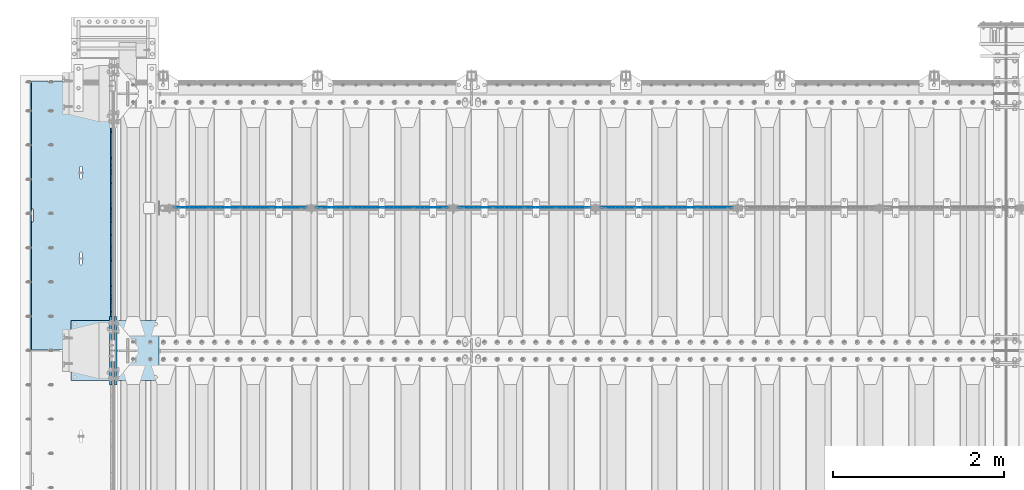
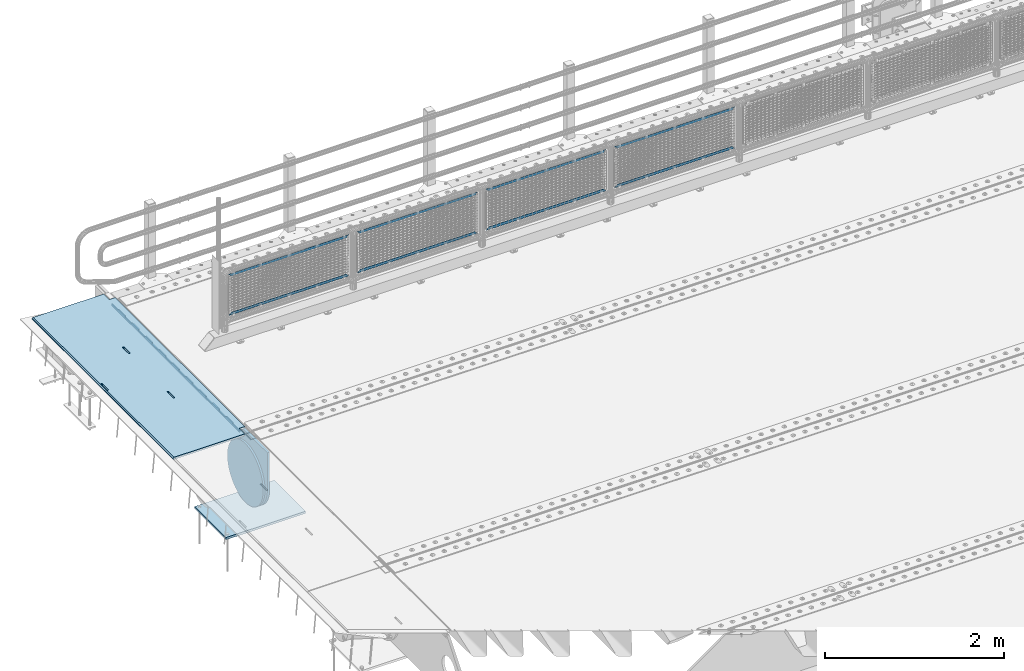
# One storey, part 188 of 240: 13 plates.
"""IFC2X3 building model written with IfcOpenShell, lengths in millimetres."""

from ifc_helpers import new_model, si_unit, frame, origin_with_axes, place, context, subcontext, project, spatial, faceted_brep, material, type_object, element, save


model = new_model("IFC2X3")

# Units and contexts
model_context = context("Model", 3, precision=1e-05, world=origin_with_axes())
body_context = subcontext(model_context, "Body", "Model", "MODEL_VIEW")
ifc_project = project(units=[si_unit("LENGTHUNIT", "METRE", prefix="MILLI"), si_unit("AREAUNIT", "SQUARE_METRE"), si_unit("VOLUMEUNIT", "CUBIC_METRE"), si_unit("MASSUNIT", "GRAM", prefix="KILO"), si_unit("TIMEUNIT", "SECOND"), si_unit("PLANEANGLEUNIT", "RADIAN"), si_unit("SOLIDANGLEUNIT", "STERADIAN"), si_unit("THERMODYNAMICTEMPERATUREUNIT", "DEGREE_CELSIUS"), si_unit("LUMINOUSINTENSITYUNIT", "LUMEN")], contexts=[model_context])

# Site, building, storey
site_placement = place(None, origin_with_axes())
site = spatial("IfcSite", under=ifc_project, at=site_placement, CompositionType="ELEMENT")
building_placement = place(site_placement, origin_with_axes())
building = spatial("IfcBuilding", under=site, at=building_placement, Name="Standard", CompositionType="ELEMENT")
storey_placement = place(building_placement, origin_with_axes())
storey = spatial("IfcBuildingStorey", under=building, at=storey_placement, Name="Undefined", CompositionType="ELEMENT", Elevation=0.0)

# Plates
ifc_material_1 = material(Name="STEEL/S355N")
plate_type_1 = type_object("IfcPlateType", PredefinedType="NOTDEFINED")
plate_1_placement = place(storey_placement, frame((42392.5, 36002.5000993725, -35.9858217417067), z_axis=(0.0, -0.999999999987744, -4.95099999993769e-06), x_axis=(0.0, 4.9510000093107e-06, -0.999999999987744)))
element("IfcPlate", 1, at=plate_1_placement, inside=storey, type_object=plate_type_1, material=ifc_material_1, context=body_context, shape_type="Brep", body=[
    faceted_brep([(7.105427357601e-15, -7.5, 0.0), (8.68993765834603e-12, -7.5, 150.000000000004), (8.68993765834603e-12, 7.5, 150.000000000004), (7.105427357601e-15, 7.5, 0.0), (-14.9999999999986, -7.5, 150.0), (-14.9999999999986, 7.5, 150.0), (-14.9999999999972, -7.5, 300.0), (-14.9999999999972, 7.5, 300.0), (1.55395696310734e-11, -7.5, 300.0), (1.55395696310734e-11, 7.5, 300.0), (1.87725390787818e-11, -7.5, 450.0), (1.87725390787818e-11, 7.5, 450.0), (-14.9999999999958, -7.5, 450.0), (-14.9999999999958, 7.5, 450.0), (-14.9999999999944, -7.5, 600.0), (-14.9999999999944, 7.5, 600.0), (2.74553713097703e-11, -7.5, 600.000000000004), (2.74553713097703e-11, 7.5, 600.000000000004), (3.24931193063094e-11, -7.5, 750.0), (3.24931193063094e-11, 7.5, 750.0), (-14.999999999993, -7.5, 750.0), (-14.999999999993, 7.5, 750.0), (-14.9999999999916, -7.5, 900.000000000004), (-14.9999999999916, 7.5, 900.000000000004), (4.11830569646554e-11, -7.5, 900.0), (4.11830569646554e-11, 7.5, 900.0), (4.62208049611945e-11, -7.5, 1050.0), (4.62208049611945e-11, 7.5, 1050.0), (-14.9999999999902, -7.5, 1050.0), (-14.9999999999902, 7.5, 1050.0), (-14.9999999999888, -7.5, 1200.0), (-14.9999999999888, 7.5, 1200.0), (5.30917532159947e-11, -7.5, 1200.0), (5.30917532159947e-11, 7.5, 1200.0), (5.99484906160797e-11, -7.5, 1350.0), (5.99484906160797e-11, 7.5, 1350.0), (-14.9999999999873, -7.5, 1350.0), (-14.9999999999873, 7.5, 1350.0), (-14.9999999999859, -7.5, 1500.0), (-14.9999999999859, 7.5, 1500.0), (6.49933440399764e-11, -7.5, 1500.0), (6.49933440399764e-11, 7.5, 1500.0), (7.36761762709648e-11, -7.5, 1650.0), (7.36761762709648e-11, 7.5, 1650.0), (-14.9999999999845, -7.5, 1650.0), (-14.9999999999845, 7.5, 1650.0), (-14.9999999999831, -7.5, 1800.0), (-14.9999999999831, 7.5, 1800.0), (7.6894934863958e-11, -7.5, 1800.0), (7.6894934863958e-11, 7.5, 1800.0), (8.37587776914006e-11, -7.5, 1950.0), (8.37587776914006e-11, 7.5, 1950.0), (-14.9999999999817, -7.5, 1950.0), (-14.9999999999817, 7.5, 1950.0), (-14.9999999999803, -7.5, 2100.0), (-14.9999999999803, 7.5, 2100.0), (9.06297259462008e-11, -7.5, 2100.0), (9.06297259462008e-11, 7.5, 2100.0), (9.56674739427399e-11, -7.5, 2250.0), (9.56674739427399e-11, 7.5, 2250.0), (-14.9999999999789, -7.5, 2250.0), (-14.9999999999789, 7.5, 2250.0), (-14.9999999999775, -7.5, 2400.0), (-14.9999999999775, 7.5, 2400.0), (1.04350306173728e-10, -7.5, 2400.0), (1.04350306173728e-10, 7.5, 2400.0), (1.09388054170267e-10, -7.5, 2550.0), (1.09388054170267e-10, 7.5, 2550.0), (-14.9999999999761, -7.5, 2550.0), (-14.9999999999761, 7.5, 2550.0), (-14.9999999999747, -7.5, 2700.0), (-14.9999999999747, 7.5, 2700.0), (1.14440013021522e-10, -7.5, 2700.0), (1.14440013021522e-10, 7.5, 2700.0), (1.23115739825153e-10, -7.5, 2850.0), (1.23115739825153e-10, 7.5, 2850.0), (25.0000000000267, -7.5, 2850.0), (25.0000000000267, 7.5, 2850.0), (25.0, -7.5, 0.0), (25.0, 7.5, 0.0)], [[[0, 1, 2, 3]], [[1, 4, 5, 2]], [[4, 6, 7, 5]], [[6, 8, 9, 7]], [[8, 10, 11, 9]], [[10, 12, 13, 11]], [[12, 14, 15, 13]], [[14, 16, 17, 15]], [[16, 18, 19, 17]], [[18, 20, 21, 19]], [[20, 22, 23, 21]], [[22, 24, 25, 23]], [[24, 26, 27, 25]], [[26, 28, 29, 27]], [[28, 30, 31, 29]], [[30, 32, 33, 31]], [[32, 34, 35, 33]], [[34, 36, 37, 35]], [[36, 38, 39, 37]], [[38, 40, 41, 39]], [[40, 42, 43, 41]], [[42, 44, 45, 43]], [[44, 46, 47, 45]], [[46, 48, 49, 47]], [[48, 50, 51, 49]], [[50, 52, 53, 51]], [[52, 54, 55, 53]], [[54, 56, 57, 55]], [[56, 58, 59, 57]], [[58, 60, 61, 59]], [[60, 62, 63, 61]], [[62, 64, 65, 63]], [[64, 66, 67, 65]], [[66, 68, 69, 67]], [[68, 70, 71, 69]], [[70, 72, 73, 71]], [[72, 74, 75, 73]], [[74, 76, 77, 75]], [[76, 78, 79, 77]], [[78, 0, 3, 79]], [[5, 7, 9, 11, 13, 15, 17, 19, 21, 23, 25, 27, 29, 31, 33, 35, 37, 39, 41, 43, 45, 47, 49, 51, 53, 55, 57, 59, 61, 63, 65, 67, 69, 71, 73, 75, 77, 79, 3, 2]], [[78, 76, 74, 72, 70, 68, 66, 64, 62, 60, 58, 56, 54, 52, 50, 48, 46, 44, 42, 40, 38, 36, 34, 32, 30, 28, 26, 24, 22, 20, 18, 16, 14, 12, 10, 8, 6, 4, 1, 0]]]),
])
plate_type_2 = type_object("IfcPlateType", PredefinedType="NOTDEFINED")
plate_2_placement = place(storey_placement, frame((42444.9962454292, 36149.9999261292, -0.984391682702986), z_axis=(0.0, -0.999999999987744, -4.95099999993769e-06), x_axis=(-0.999999999879068, -1.00000022173607e-09, -1.55519999981193e-05)))
element("IfcPlate", 2, at=plate_2_placement, inside=storey, type_object=plate_type_2, material=ifc_material_1, context=body_context, shape_type="Brep", body=[
    faceted_brep([(14.9998601691696, 15.0, 125.000024820834), (-0.000294611330900807, -0.000806902962787959, 124.999936248634), (-0.00191941577213584, 0.000806844426835429, 3020.00000492305), (14.9966216875182, 15.0, 3020.00007976653), (999.996459960938, 5.0, 0.0), (984.996459960938, 15.0, 3.63797880709171e-12), (984.996459718786, 15.0, 3145.0), (999.996459718786, 5.0, 3145.0), (984.996459961367, -15.0, 0.0), (999.996459960938, -4.99999999999849, 0.0), (999.996459718786, -4.99999999999849, 3145.0), (984.996459719216, -15.0, 3145.0), (74.9997820615827, -15.0, 0.0), (74.999642186689, -15.0000000127077, 124.999930084101), (75.000108716682, 15.0, 125.000079754103), (75.0002485915757, 15.0, 0.0), (-0.000449375198513735, -14.9999999951864, 124.999861417746), (395.486056604284, -15.0000000067239, 2004.40983005401), (395.486056604284, 15.0, 2004.409830054), (394.996621766993, 15.0, 2007.49999999776), (394.996621766993, -15.0000000067363, 2007.49999999776), (396.906451823692, -15.0000000066914, 2001.62214747483), (396.906451823699, 15.0, 2001.62214747483), (399.118769244698, -15.0000000066418, 1999.40983005401), (399.118769244691, 15.0, 1999.40983005401), (401.906451823976, -15.0000000065801, 1997.98943483481), (401.906451823968, 15.0, 1997.98943483481), (404.996621767765, -15.0000000065123, 1997.49999999776), (404.996621767765, 15.0, 1997.49999999776), (408.086791711365, -15.0000000064451, 1997.9894348348), (408.086791711365, 15.0, 1997.9894348348), (410.874474290416, -15.0000000063849, 1999.40983005401), (410.874474290416, 15.0, 1999.409830054), (413.086791711074, -15.0000000063378, 2001.62214747483), (413.086791711074, 15.0, 2001.62214747483), (414.507186930074, -15.0000000063082, 2004.409830054), (414.507186930066, 15.0, 2004.409830054), (414.996621766884, -15.0000000062992, 2007.49999999775), (414.996621766884, 15.0, 2007.49999999774), (414.996621756967, -15.0000000063698, 2137.49999999774), (414.996621756967, 15.0, 2137.49999999774), (414.507186919684, -15.0000000063821, 2140.5901699415), (414.507186919676, 15.0, 2140.59016994149), (413.086791700262, -15.0000000064147, 2143.37785252068), (413.086791700269, 15.0, 2143.37785252068), (410.874474279262, -15.0000000064642, 2145.59016994151), (410.874474279262, 15.0, 2145.5901699415), (408.086791699985, -15.0000000065259, 2147.01056516071), (408.086791699985, 15.0, 2147.01056516071), (404.996621756196, -15.0000000065937, 2147.49999999776), (404.996621756196, 15.0, 2147.49999999776), (401.906451812487, -15.000000006661, 2147.01056516071), (401.90645181248, 15.0, 2147.01056516071), (399.118769233428, -15.0000000067211, 2145.59016994151), (399.118769233428, 15.0, 2145.5901699415), (396.906451812771, -15.0000000067683, 2143.37785252068), (396.906451812771, 15.0, 2143.37785252068), (395.486056593785, -15.0000000067978, 2140.5901699415), (395.486056593785, 15.0, 2140.5901699415), (394.996621756974, -15.0000000068068, 2137.49999999776), (394.996621756974, 15.0, 2137.49999999776), (960.486056642774, -14.9999999941054, 1504.40983005425), (960.486056642774, 15.0, 1504.40983005424), (959.996621805491, 15.0, 1507.49999999799), (959.996621805483, -14.9999999941178, 1507.499999998), (961.906451862204, -14.9999999940729, 1501.62214747506), (961.906451862204, 15.0, 1501.62214747507), (964.118769283195, -14.9999999940233, 1499.40983005424), (964.118769283188, 15.0, 1499.40983005425), (966.906451862473, -14.9999999939616, 1497.98943483504), (966.906451862473, 15.0, 1497.98943483504), (969.996621806262, -14.9999999938938, 1497.49999999799), (969.996621806262, 15.0, 1497.49999999799), (973.086791749862, -14.9999999938266, 1497.98943483504), (973.086791749862, 15.0, 1497.98943483504), (975.874474328921, -14.9999999937664, 1499.40983005424), (975.874474328921, 15.0, 1499.40983005424), (978.086791749585, -14.9999999937193, 1501.62214747506), (978.086791749585, 15.0, 1501.62214747506), (979.507186968563, -14.9999999936897, 1504.40983005424), (979.507186968556, 15.0, 1504.40983005424), (979.996621805374, -14.9999999936807, 1507.49999999798), (979.996621805374, 15.0, 1507.49999999798), (979.996621795464, -14.9999999937513, 1637.49999999798), (979.996621795464, 15.0, 1637.49999999798), (979.507186958181, -14.9999999937636, 1640.59016994174), (979.507186958181, 15.0, 1640.59016994174), (978.086791738766, -14.9999999937962, 1643.37785252092), (978.086791738766, 15.0, 1643.37785252092), (975.874474317767, -14.9999999938457, 1645.59016994174), (975.874474317767, 15.0, 1645.59016994174), (973.086791738482, -14.9999999939074, 1647.01056516095), (973.086791738482, 15.0, 1647.01056516094), (969.996621794686, -14.9999999939752, 1647.499999998), (969.996621794693, 15.0, 1647.499999998), (966.906451850984, -14.9999999940425, 1647.01056516094), (966.906451850984, 15.0, 1647.01056516094), (964.118769271925, -14.9999999941026, 1645.59016994174), (964.118769271925, 15.0, 1645.59016994174), (961.906451851268, -14.9999999941498, 1643.37785252092), (961.906451851268, 15.0, 1643.37785252092), (960.486056632282, -14.9999999941793, 1640.59016994174), (960.486056632282, 15.0, 1640.59016994174), (959.996621795472, -14.9999999941883, 1637.49999999799), (959.996621795472, 15.0, 1637.49999999799), (74.9967306509934, 15.0, 3145.0), (74.9962640909871, -15.0, 3145.0), (74.9968705258798, 15.0, 3020.00007982413), (74.9964039658807, -15.0, 3019.99993015413), (-0.00046036208368605, -15.00000004538, 3019.99993008592), (395.486056670779, -15.0000000062551, 1140.59016994198), (396.906451889758, -15.0000000062256, 1143.37785252116), (399.118769310422, -15.0000000061784, 1145.59016994199), (401.906451889488, -15.0000000061183, 1147.0105651612), (404.99662183319, -15.000000006051, 1147.49999999824), (408.086791776979, -15.0000000059832, 1147.01056516119), (410.874474356264, -15.0000000059215, 1145.59016994199), (413.086791777256, -15.000000005872, 1143.37785252116), (414.507186996685, -15.0000000058394, 1140.59016994198), (414.996621833961, -15.0000000058271, 1137.49999999823), (414.996621843871, -15.0000000057565, 1007.49999999823), (414.507187007061, -15.0000000057655, 1004.40983005448), (413.086791788075, -15.0000000057951, 1001.62214747531), (410.874474367418, -15.0000000058422, 999.40983005449), (408.086791788359, -15.0000000059024, 997.989434835286), (404.996621844759, -15.0000000059696, 997.499999998239), (401.906451900977, -15.0000000060374, 997.989434835294), (399.118769321693, -15.0000000060991, 999.40983005449), (396.906451900693, -15.0000000061487, 1001.62214747531), (395.486056681271, -15.0000000061812, 1004.40983005449), (394.996621843988, -15.0000000061936, 1007.49999999824), (394.996621833969, -15.0000000062641, 1137.49999999824), (396.906451900693, 15.0, 1001.62214747531), (395.486056681271, 15.0, 1004.40983005448), (399.118769321685, 15.0, 999.40983005449), (401.90645190097, 15.0, 997.98943483529), (404.996621844759, 15.0, 997.499999998236), (408.086791788359, 15.0, 997.989434835286), (410.874474367418, 15.0, 999.409830054487), (413.086791788075, 15.0, 1001.62214747531), (414.507187007061, 15.0, 1004.40983005448), (414.996621843879, 15.0, 1007.49999999823), (414.996621833961, 15.0, 1137.49999999823), (414.507186996678, 15.0, 1140.59016994198), (413.086791777256, 15.0, 1143.37785252116), (410.874474356264, 15.0, 1145.59016994199), (408.086791776979, 15.0, 1147.01056516119), (404.99662183319, 15.0, 1147.49999999824), (401.906451889481, 15.0, 1147.01056516119), (399.118769310422, 15.0, 1145.59016994199), (396.906451889758, 15.0, 1143.37785252116), (395.486056670779, 15.0, 1140.59016994198), (394.996621833969, 15.0, 1137.49999999824), (394.996621843988, 15.0, 1007.49999999824)], [[[0, 1, 2, 3]], [[4, 5, 6, 7]], [[8, 9, 10, 11]], [[12, 13, 14, 15]], [[14, 13, 16, 1, 0]], [[17, 18, 19, 20]], [[21, 22, 18, 17]], [[23, 24, 22, 21]], [[25, 26, 24, 23]], [[27, 28, 26, 25]], [[29, 30, 28, 27]], [[31, 32, 30, 29]], [[33, 34, 32, 31]], [[35, 36, 34, 33]], [[37, 38, 36, 35]], [[39, 40, 38, 37]], [[41, 42, 40, 39]], [[43, 44, 42, 41]], [[45, 46, 44, 43]], [[47, 48, 46, 45]], [[49, 50, 48, 47]], [[51, 52, 50, 49]], [[53, 54, 52, 51]], [[55, 56, 54, 53]], [[57, 58, 56, 55]], [[59, 60, 58, 57]], [[20, 19, 60, 59]], [[61, 62, 63, 64]], [[65, 66, 62, 61]], [[67, 68, 66, 65]], [[69, 70, 68, 67]], [[71, 72, 70, 69]], [[73, 74, 72, 71]], [[75, 76, 74, 73]], [[77, 78, 76, 75]], [[79, 80, 78, 77]], [[81, 82, 80, 79]], [[83, 84, 82, 81]], [[85, 86, 84, 83]], [[87, 88, 86, 85]], [[89, 90, 88, 87]], [[91, 92, 90, 89]], [[93, 94, 92, 91]], [[95, 96, 94, 93]], [[97, 98, 96, 95]], [[99, 100, 98, 97]], [[101, 102, 100, 99]], [[103, 104, 102, 101]], [[64, 63, 104, 103]], [[9, 8, 12, 15, 5, 4]], [[10, 9, 4, 7]], [[105, 106, 11, 10, 7, 6]], [[106, 105, 107, 108]], [[109, 108, 107, 3, 2]], [[106, 108, 109, 16, 13, 12, 8, 11], [101, 99, 97, 95, 93, 91, 89, 87, 85, 83, 81, 79, 77, 75, 73, 71, 69, 67, 65, 61, 64, 103], [57, 55, 53, 51, 49, 47, 45, 43, 41, 39, 37, 35, 33, 31, 29, 27, 25, 23, 21, 17, 20, 59], [110, 111, 112, 113, 114, 115, 116, 117, 118, 119, 120, 121, 122, 123, 124, 125, 126, 127, 128, 129, 130, 131]], [[128, 132, 133, 129]], [[127, 134, 132, 128]], [[126, 135, 134, 127]], [[125, 136, 135, 126]], [[124, 137, 136, 125]], [[123, 138, 137, 124]], [[122, 139, 138, 123]], [[121, 140, 139, 122]], [[120, 141, 140, 121]], [[119, 142, 141, 120]], [[118, 143, 142, 119]], [[117, 144, 143, 118]], [[116, 145, 144, 117]], [[115, 146, 145, 116]], [[114, 147, 146, 115]], [[113, 148, 147, 114]], [[112, 149, 148, 113]], [[111, 150, 149, 112]], [[110, 151, 150, 111]], [[131, 152, 151, 110]], [[130, 153, 152, 131]], [[129, 133, 153, 130]], [[107, 105, 6, 5, 15, 14, 0, 3], [132, 134, 135, 136, 137, 138, 139, 140, 141, 142, 143, 144, 145, 146, 147, 148, 149, 150, 151, 152, 153, 133], [22, 24, 26, 28, 30, 32, 34, 36, 38, 40, 42, 44, 46, 48, 50, 52, 54, 56, 58, 60, 19, 18], [66, 68, 70, 72, 74, 76, 78, 80, 82, 84, 86, 88, 90, 92, 94, 96, 98, 100, 102, 104, 63, 62]], [[16, 109, 2, 1]]]),
])
ifc_material_2 = material(Name="Misc_Undefined")
plate_type_3 = type_object("IfcPlateType", PredefinedType="NOTDEFINED")
plate_3_placement = place(storey_placement, frame((48098.5050117304, 34670.5, 351.520303374641), z_axis=(0.0, 0.0, 1.0), x_axis=(1.0, 0.0, 0.0)))
element("IfcPlate", 3, at=plate_3_placement, inside=storey, type_object=plate_type_3, material=ifc_material_2, context=body_context, shape_type="Brep", body=[
    faceted_brep([(-7.27595761418343e-12, -1.49999999999272, 0.0), (35.000297546394, -1.5, 34.9996948242186), (35.000297546394, 1.5, 34.9996948242186), (0.0, 1.50000000000728, 0.0), (1515.99035644533, -1.5, 34.9999923706054), (1515.99035644533, 1.5, 34.9999923706054), (1550.98999023439, -1.5, 4.43031922259252e-09), (1550.98999023439, 1.5, 4.43031922259252e-09)], [[[0, 1, 2, 3]], [[1, 4, 5, 2]], [[4, 6, 7, 5]], [[6, 0, 3, 7]], [[5, 7, 3, 2]], [[6, 4, 1, 0]]]),
])
plate_4_placement = place(storey_placement, frame((49649.5000001876, 34670.5, 914.520000175701), z_axis=(-0.707103624179501, 0.0, 0.707109938179499), x_axis=(-0.707109938179504, 0.0, -0.707103624179496)))
element("IfcPlate", 4, at=plate_4_placement, inside=storey, type_object=plate_type_3, material=ifc_material_2, context=body_context, shape_type="Brep", body=[
    faceted_brep([(-7.27595761418343e-12, -1.49999999999272, 0.0), (1096.72753906249, -1.5, 1096.7177734375), (1096.72753906249, 1.5, 1096.7177734375), (0.0, 1.50000000000728, 0.0), (1096.72045898437, -1.5, 1047.21337890625), (1096.72045898437, 1.5, 1047.21337890625), (49.4976959228443, -1.5, -1.09139364212751e-10), (49.4976959228443, 1.5, -1.09139364212751e-10)], [[[0, 1, 2, 3]], [[1, 4, 5, 2]], [[4, 6, 7, 5]], [[6, 0, 3, 7]], [[5, 7, 3, 2]], [[6, 4, 1, 0]]]),
])
plate_5_placement = place(storey_placement, frame((46440.5050117304, 34670.5, 351.520303374641), z_axis=(0.0, 0.0, 1.0), x_axis=(1.0, 0.0, 0.0)))
element("IfcPlate", 5, at=plate_5_placement, inside=storey, type_object=plate_type_3, material=ifc_material_2, context=body_context, shape_type="Brep", body=[
    faceted_brep([(-7.27595761418343e-12, -1.49999999999272, 0.0), (35.000297546394, -1.5, 34.9996948242186), (35.000297546394, 1.5, 34.9996948242186), (0.0, 1.50000000000728, 0.0), (1515.99035644533, -1.5, 34.9999923706054), (1515.99035644533, 1.5, 34.9999923706054), (1550.98999023439, -1.5, 4.43031922259252e-09), (1550.98999023439, 1.5, 4.43031922259252e-09)], [[[0, 1, 2, 3]], [[1, 4, 5, 2]], [[4, 6, 7, 5]], [[6, 0, 3, 7]], [[5, 7, 3, 2]], [[6, 4, 1, 0]]]),
])
plate_6_placement = place(storey_placement, frame((47991.5000001876, 34670.5, 914.520000175701), z_axis=(-0.707103624179501, 0.0, 0.707109938179499), x_axis=(-0.707109938179504, 0.0, -0.707103624179496)))
element("IfcPlate", 6, at=plate_6_placement, inside=storey, type_object=plate_type_3, material=ifc_material_2, context=body_context, shape_type="Brep", body=[
    faceted_brep([(-7.27595761418343e-12, -1.49999999999272, 0.0), (1096.72753906249, -1.5, 1096.7177734375), (1096.72753906249, 1.5, 1096.7177734375), (0.0, 1.50000000000728, 0.0), (1096.72045898437, -1.5, 1047.21337890625), (1096.72045898437, 1.5, 1047.21337890625), (49.4976959228443, -1.5, -1.09139364212751e-10), (49.4976959228443, 1.5, -1.09139364212751e-10)], [[[0, 1, 2, 3]], [[1, 4, 5, 2]], [[4, 6, 7, 5]], [[6, 0, 3, 7]], [[5, 7, 3, 2]], [[6, 4, 1, 0]]]),
])
plate_7_placement = place(storey_placement, frame((44782.5050117304, 34670.5, 351.520303374641), z_axis=(0.0, 0.0, 1.0), x_axis=(1.0, 0.0, 0.0)))
element("IfcPlate", 7, at=plate_7_placement, inside=storey, type_object=plate_type_3, material=ifc_material_2, context=body_context, shape_type="Brep", body=[
    faceted_brep([(-7.27595761418343e-12, -1.49999999999272, 0.0), (35.000297546394, -1.5, 34.9996948242186), (35.000297546394, 1.5, 34.9996948242186), (0.0, 1.50000000000728, 0.0), (1515.99035644533, -1.5, 34.9999923706054), (1515.99035644533, 1.5, 34.9999923706054), (1550.98999023439, -1.5, 4.43031922259252e-09), (1550.98999023439, 1.5, 4.43031922259252e-09)], [[[0, 1, 2, 3]], [[1, 4, 5, 2]], [[4, 6, 7, 5]], [[6, 0, 3, 7]], [[5, 7, 3, 2]], [[6, 4, 1, 0]]]),
])
plate_8_placement = place(storey_placement, frame((46333.5000001876, 34670.5, 914.520000175701), z_axis=(-0.707103624179501, 0.0, 0.707109938179499), x_axis=(-0.707109938179504, 0.0, -0.707103624179496)))
element("IfcPlate", 8, at=plate_8_placement, inside=storey, type_object=plate_type_3, material=ifc_material_2, context=body_context, shape_type="Brep", body=[
    faceted_brep([(-7.27595761418343e-12, -1.49999999999272, 0.0), (1096.72753906249, -1.5, 1096.7177734375), (1096.72753906249, 1.5, 1096.7177734375), (0.0, 1.50000000000728, 0.0), (1096.72045898437, -1.5, 1047.21337890625), (1096.72045898437, 1.5, 1047.21337890625), (49.4976959228443, -1.5, -1.09139364212751e-10), (49.4976959228443, 1.5, -1.09139364212751e-10)], [[[0, 1, 2, 3]], [[1, 4, 5, 2]], [[4, 6, 7, 5]], [[6, 0, 3, 7]], [[5, 7, 3, 2]], [[6, 4, 1, 0]]]),
])
plate_9_placement = place(storey_placement, frame((43124.5050117304, 34670.5, 351.520303374641), z_axis=(0.0, 0.0, 1.0), x_axis=(1.0, 0.0, 0.0)))
element("IfcPlate", 9, at=plate_9_placement, inside=storey, type_object=plate_type_3, material=ifc_material_2, context=body_context, shape_type="Brep", body=[
    faceted_brep([(-7.27595761418343e-12, -1.49999999999272, 0.0), (35.000297546394, -1.5, 34.9996948242186), (35.000297546394, 1.5, 34.9996948242186), (0.0, 1.50000000000728, 0.0), (1515.99035644533, -1.5, 34.9999923706054), (1515.99035644533, 1.5, 34.9999923706054), (1550.98999023439, -1.5, 4.43031922259252e-09), (1550.98999023439, 1.5, 4.43031922259252e-09)], [[[0, 1, 2, 3]], [[1, 4, 5, 2]], [[4, 6, 7, 5]], [[6, 0, 3, 7]], [[5, 7, 3, 2]], [[6, 4, 1, 0]]]),
])
plate_10_placement = place(storey_placement, frame((44675.5000001876, 34670.5, 914.520000175701), z_axis=(-0.707103624179501, 0.0, 0.707109938179499), x_axis=(-0.707109938179504, 0.0, -0.707103624179496)))
element("IfcPlate", 10, at=plate_10_placement, inside=storey, type_object=plate_type_3, material=ifc_material_2, context=body_context, shape_type="Brep", body=[
    faceted_brep([(-7.27595761418343e-12, -1.49999999999272, 0.0), (1096.72753906249, -1.5, 1096.7177734375), (1096.72753906249, 1.5, 1096.7177734375), (0.0, 1.50000000000728, 0.0), (1096.72045898437, -1.5, 1047.21337890625), (1096.72045898437, 1.5, 1047.21337890625), (49.4976959228443, -1.5, -1.09139364212751e-10), (49.4976959228443, 1.5, -1.09139364212751e-10)], [[[0, 1, 2, 3]], [[1, 4, 5, 2]], [[4, 6, 7, 5]], [[6, 0, 3, 7]], [[5, 7, 3, 2]], [[6, 4, 1, 0]]]),
])
plate_type_4 = type_object("IfcPlateType", PredefinedType="NOTDEFINED")
plate_11_placement = place(storey_placement, frame((41926.0, 33350.0, -1043.0), z_axis=(1.0, 0.0, 0.0), x_axis=(0.0, -1.0, 0.0)))
element("IfcPlate", 11, at=plate_11_placement, inside=storey, type_object=plate_type_4, material=ifc_material_1, context=body_context, shape_type="Brep", body=[
    faceted_brep([(0.0, -15.0, 0.0), (3.03448323393241e-05, -15.0, 1025.0), (3.03448323393241e-05, 15.0, 1025.0), (0.0, 15.0, 0.0), (700.0, -15.0, 1025.0), (700.0, 15.0, 1025.0), (700.0, -15.0, -7.27595761418343e-12), (700.0, 15.0, -7.27595761418343e-12)], [[[0, 1, 2, 3]], [[1, 4, 5, 2]], [[4, 6, 7, 5]], [[6, 0, 3, 7]], [[5, 7, 3, 2]], [[6, 4, 1, 0]]]),
])
plate_type_5 = type_object("IfcPlateType", PredefinedType="NOTDEFINED")
plate_12_placement = place(storey_placement, frame((42387.5, 33400.0, -114.999999999998), z_axis=(0.0, 0.0, -1.0), x_axis=(0.0, -1.0, 0.0)))
element("IfcPlate", 12, at=plate_12_placement, inside=storey, type_object=plate_type_5, material=ifc_material_1, context=body_context, shape_type="Brep", body=[
    faceted_brep([(0.0, -12.5, 400.0), (2.91645036072441, -12.5, 448.214672101647), (2.91645036072441, 12.5, 448.214672101647), (0.0, 12.5, 400.0), (11.6232730294796, -12.5, 495.726265714562), (11.6232730294796, 12.5, 495.726265714562), (25.9935029256958, -12.5, 541.841954816598), (25.9935029256958, 12.5, 541.841954816598), (45.8175897385445, -12.5, 585.889268817169), (45.8175897385445, 12.5, 585.889268817169), (70.8064536423408, -12.5, 627.22589869221), (70.8064536423408, 12.5, 627.22589869221), (100.595700731341, -12.5, 665.24906329616), (100.595700731341, 12.5, 665.24906329616), (134.750936703451, -12.5, 699.40429926839), (134.750936703451, 12.5, 699.40429926839), (172.774101307281, -12.5, 729.193546357525), (172.774101307281, 12.5, 729.193546357525), (214.11073118222, -12.5, 754.182410261448), (214.11073118222, 12.5, 754.182410261448), (258.158045182681, -12.5, 774.006497074428), (258.158045182681, 12.5, 774.006497074428), (304.273734284623, -12.5, 788.376726970779), (304.273734284623, 12.5, 788.376726970779), (351.785327897465, -12.5, 797.083549639658), (351.785327897465, 12.5, 797.083549639658), (400.0, -12.5, 800.0), (400.0, 12.5, 800.0), (448.21467210335, -12.5, 797.083549637646), (448.21467210335, 12.5, 797.083549637646), (495.726265715995, -12.5, 788.37672696916), (495.726265715995, 12.5, 788.37672696916), (541.841954817748, -12.5, 774.006497073235), (541.841954817748, 12.5, 774.006497073235), (585.889268818006, -12.5, 754.182410260695), (585.889268818006, 12.5, 754.182410260695), (627.225898692734, -12.5, 729.193546357212), (627.225898692734, 12.5, 729.193546357212), (665.24906329636, -12.5, 699.404299268539), (665.24906329636, 12.5, 699.404299268539), (699.404299268259, -12.5, 665.24906329676), (699.404299268259, 12.5, 665.24906329676), (729.193546357063, -12.5, 627.22589869325), (729.193546357063, 12.5, 627.22589869325), (754.18241026067, -12.5, 585.889268818639), (754.18241026067, 12.5, 585.889268818639), (774.006497073351, -12.5, 541.841954818479), (774.006497073351, 12.5, 541.841954818479), (788.376726969393, -12.5, 495.726265716821), (788.376726969393, 12.5, 495.726265716821), (797.083549638002, -12.5, 448.214672104252), (797.083549638002, 12.5, 448.214672104252), (800.0, -12.5, 400.0), (800.0, 12.5, 400.0), (797.083549639283, -12.5, 351.785327898364), (797.083549639283, 12.5, 351.785327898364), (788.376726970528, -12.5, 304.273734285453), (788.376726970528, 12.5, 304.273734285453), (774.006497074311, -12.5, 258.158045183416), (774.006497074311, 12.5, 258.158045183416), (754.182410261463, -12.5, 214.110731182853), (754.182410261463, 12.5, 214.110731182853), (729.193546357659, -12.5, 172.774101307812), (729.193546357659, 12.5, 172.774101307812), (699.404299268659, -12.5, 134.750936703855), (699.404299268659, 12.5, 134.750936703855), (665.249063296564, -12.5, 100.595700731628), (665.249063296564, 12.5, 100.595700731628), (627.225898692719, -12.5, 70.8064536425045), (627.225898692719, 12.5, 70.8064536425045), (585.889268817788, -12.5, 45.8175897385809), (585.889268817788, 12.5, 45.8175897385809), (541.841954817326, -12.5, 25.9935029256012), (541.841954817326, 12.5, 25.9935029256012), (495.726265715377, -12.5, 11.6232730292504), (495.726265715377, 12.5, 11.6232730292504), (448.214672102542, -12.5, 2.91645036037517), (448.214672102542, 12.5, 2.91645036037517), (400.0, -12.5, -5.6843418860808e-14), (400.0, 12.5, -5.6843418860808e-14), (351.785327896665, -12.5, 2.91645036236514), (351.785327896665, 12.5, 2.91645036236514), (304.273734284012, -12.5, 11.6232730308511), (304.273734284012, 12.5, 11.6232730308511), (258.158045182267, -12.5, 25.9935029267763), (258.158045182267, 12.5, 25.9935029267763), (214.110731182009, -12.5, 45.8175897393157), (214.110731182009, 12.5, 45.8175897393157), (172.774101307281, -12.5, 70.8064536427992), (172.774101307281, 12.5, 70.8064536427992), (134.750936703655, -12.5, 100.595700731472), (134.750936703655, 12.5, 100.595700731472), (100.595700731748, -12.5, 134.750936703247), (100.595700731748, 12.5, 134.750936703247), (70.8064536429447, -12.5, 172.774101306761), (70.8064536429447, 12.5, 172.774101306761), (45.8175897393376, -12.5, 214.110731181379), (45.8175897393376, 12.5, 214.110731181379), (25.9935029266635, -12.5, 258.158045181532), (25.9935029266635, 12.5, 258.158045181532), (11.6232730306074, -12.5, 304.273734283186), (11.6232730306074, 12.5, 304.273734283186), (2.9164503619977, -12.5, 351.785327895759), (2.9164503619977, 12.5, 351.785327895759)], [[[0, 1, 2, 3]], [[1, 4, 5, 2]], [[4, 6, 7, 5]], [[6, 8, 9, 7]], [[8, 10, 11, 9]], [[10, 12, 13, 11]], [[12, 14, 15, 13]], [[14, 16, 17, 15]], [[16, 18, 19, 17]], [[18, 20, 21, 19]], [[20, 22, 23, 21]], [[22, 24, 25, 23]], [[24, 26, 27, 25]], [[26, 28, 29, 27]], [[28, 30, 31, 29]], [[30, 32, 33, 31]], [[32, 34, 35, 33]], [[34, 36, 37, 35]], [[36, 38, 39, 37]], [[38, 40, 41, 39]], [[40, 42, 43, 41]], [[42, 44, 45, 43]], [[44, 46, 47, 45]], [[46, 48, 49, 47]], [[48, 50, 51, 49]], [[50, 52, 53, 51]], [[52, 54, 55, 53]], [[54, 56, 57, 55]], [[56, 58, 59, 57]], [[58, 60, 61, 59]], [[60, 62, 63, 61]], [[62, 64, 65, 63]], [[64, 66, 67, 65]], [[66, 68, 69, 67]], [[68, 70, 71, 69]], [[70, 72, 73, 71]], [[72, 74, 75, 73]], [[74, 76, 77, 75]], [[76, 78, 79, 77]], [[78, 80, 81, 79]], [[80, 82, 83, 81]], [[82, 84, 85, 83]], [[84, 86, 87, 85]], [[86, 88, 89, 87]], [[88, 90, 91, 89]], [[90, 92, 93, 91]], [[92, 94, 95, 93]], [[94, 96, 97, 95]], [[96, 98, 99, 97]], [[98, 100, 101, 99]], [[100, 102, 103, 101]], [[102, 0, 3, 103]], [[5, 7, 9, 11, 13, 15, 17, 19, 21, 23, 25, 27, 29, 31, 33, 35, 37, 39, 41, 43, 45, 47, 49, 51, 53, 55, 57, 59, 61, 63, 65, 67, 69, 71, 73, 75, 77, 79, 81, 83, 85, 87, 89, 91, 93, 95, 97, 99, 101, 103, 3, 2]], [[102, 100, 98, 96, 94, 92, 90, 88, 86, 84, 82, 80, 78, 76, 74, 72, 70, 68, 66, 64, 62, 60, 58, 56, 54, 52, 50, 48, 46, 44, 42, 40, 38, 36, 34, 32, 30, 28, 26, 24, 22, 20, 18, 16, 14, 12, 10, 8, 6, 4, 1, 0]]]),
])
plate_type_6 = type_object("IfcPlateType", PredefinedType="NOTDEFINED")
plate_13_placement = place(storey_placement, frame((42445.0, 32600.0, -20.0), z_axis=(0.0, 1.0, 0.0), x_axis=(0.0, 0.0, -1.0)))
element("IfcPlate", 13, at=plate_13_placement, inside=storey, type_object=plate_type_6, material=ifc_material_1, context=body_context, shape_type="Brep", body=[
    faceted_brep([(855.0, -15.0, 572.96311467154), (855.0, 15.0, 572.96311467154), (849.182410261294, 15.0, 585.889268817533), (849.182410261294, -15.0, 585.889268817533), (824.193546357474, 15.0, 627.225898692486), (824.193546357474, -15.0, 627.225898692486), (794.404299268454, 15.0, 665.249063296338), (794.404299268454, -15.0, 665.249063296338), (760.249063296334, 15.0, 699.404299268463), (760.249063296334, -15.0, 699.404299268463), (722.22589869248, 15.0, 729.193546357485), (722.22589869248, -15.0, 729.193546357485), (680.889268817528, 15.0, 754.18241026131), (680.889268817528, -15.0, 754.18241026131), (636.841954817037, 15.0, 774.006497074195), (636.841954817037, -15.0, 774.006497074195), (590.726265715048, 15.0, 788.376726970448), (590.726265715048, -15.0, 788.376726970448), (543.214672102156, 15.0, 797.083549639254), (543.214672102156, -15.0, 797.083549639254), (495.0, -15.0, 800.000000000029), (495.0, 15.0, 800.0), (494.999999999412, -15.0, 0.0), (494.999999999412, 15.0, 0.0), (543.214672102129, 15.0, 2.91645036080809), (543.214672102129, -15.0, 2.91645036080809), (590.726265715023, 15.0, 11.6232730296069), (590.726265715023, -15.0, 11.6232730296069), (636.841954817014, 15.0, 25.9935029258631), (636.841954817014, -15.0, 25.9935029258631), (680.889268817507, 15.0, 45.8175897387446), (680.889268817507, -15.0, 45.8175897387446), (722.225898692462, 15.0, 70.8064536425663), (722.225898692462, -15.0, 70.8064536425663), (760.249063296318, 15.0, 100.595700731588), (760.249063296318, -15.0, 100.595700731588), (794.404299268441, 15.0, 134.750936703713), (794.404299268441, -15.0, 134.750936703713), (824.193546357463, 15.0, 172.774101307565), (824.193546357463, -15.0, 172.774101307565), (849.182410261284, 15.0, 214.110731182518), (849.182410261284, -15.0, 214.110731182518), (855.0, -15.0, 227.036885328533), (855.0, 15.0, 227.036885328533), (0.0, -15.0, 0.0), (0.0, 15.0, 0.0), (0.0, 15.0, 800.0), (0.0, -15.0, 800.0)], [[[0, 1, 2, 3]], [[3, 2, 4, 5]], [[5, 4, 6, 7]], [[7, 6, 8, 9]], [[9, 8, 10, 11]], [[11, 10, 12, 13]], [[13, 12, 14, 15]], [[15, 14, 16, 17]], [[17, 16, 18, 19]], [[20, 19, 18, 21]], [[22, 23, 24, 25]], [[25, 24, 26, 27]], [[27, 26, 28, 29]], [[29, 28, 30, 31]], [[31, 30, 32, 33]], [[33, 32, 34, 35]], [[35, 34, 36, 37]], [[37, 36, 38, 39]], [[39, 38, 40, 41]], [[42, 41, 40, 43]], [[42, 43, 1, 0]], [[44, 45, 23, 22]], [[16, 14, 12, 10, 8, 6, 4, 2, 1, 43, 40, 38, 36, 34, 32, 30, 28, 26, 24, 23, 45, 46, 21, 18]], [[44, 47, 46, 45]], [[46, 47, 20, 21]], [[47, 44, 22, 25, 27, 29, 31, 33, 35, 37, 39, 41, 42, 0, 3, 5, 7, 9, 11, 13, 15, 17, 19, 20]]]),
])

save(model, "model.ifc")
